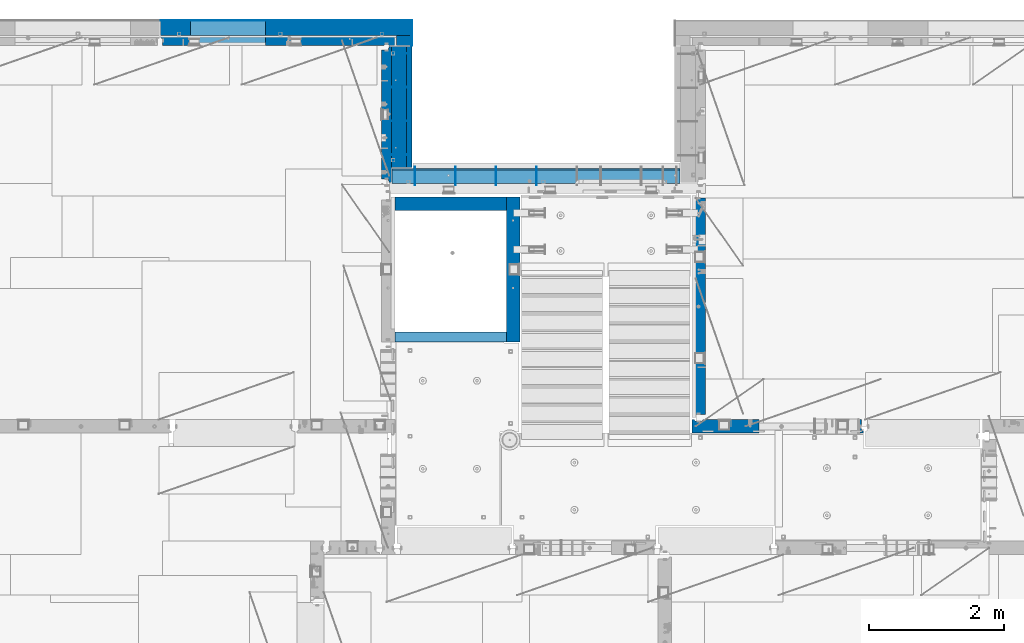
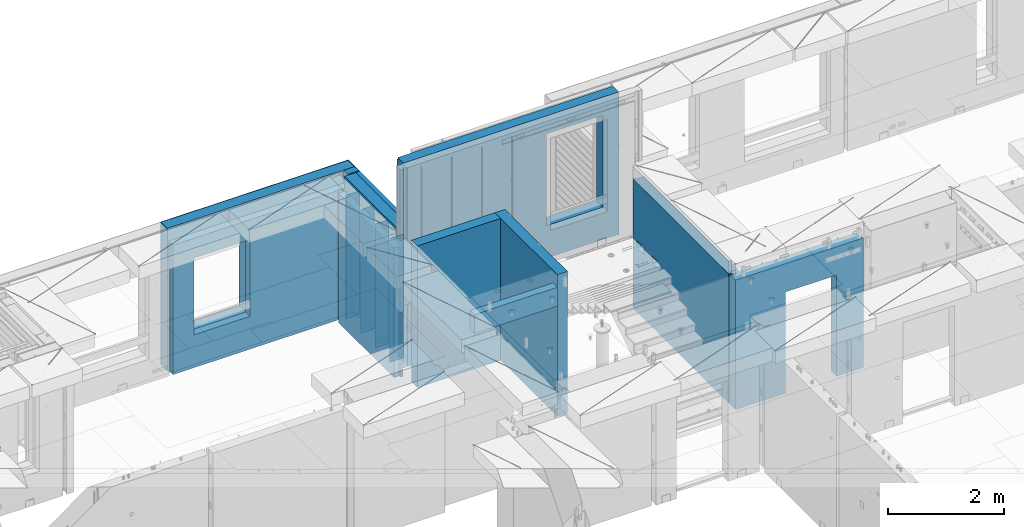
# One storey, part 237 of 349: 22 walls, 7 elements without a shape of their own.
"""IFC2X3 building model written with IfcOpenShell, lengths in millimetres."""

import ifcopenshell
import ifcopenshell.guid

model = None  # the IFC model being written
_history = None  # IfcOwnerHistory: only IFC2X3 demands one
_inside = {}  # id of a spatial element -> (the spatial element, [elements in it])
_under = {}  # id of a project, library or spatial element -> (it, [spatial elements below it])
_declared = {}  # id of a project -> (the project, [libraries it declares])
_typed = {}  # id of a type object -> (the type object, [elements of that type])
_made_of = {}  # id of a material, layer set ... -> (it, [elements and type objects made of it])


def new_model(schema):
    """Start an empty IFC model of exactly this schema.

    Asked for "IFC4X3", IfcOpenShell would pick the latest addendum, in which some entities
    have other attributes; the version numbers below select the first issue.
    IFC2X3 requires an IfcOwnerHistory on every rooted entity: one is made here for all.
    """
    global model, _history
    if schema == "IFC4X3":
        model = ifcopenshell.file(schema_version=(4, 3, 0, 0))
    else:
        model = ifcopenshell.file(schema=schema)
    _inside.clear()
    _under.clear()
    _declared.clear()
    _typed.clear()
    _made_of.clear()
    _history = None
    if model.schema == "IFC2X3":
        org = make("IfcOrganization", Name="unknown")
        user = make(
            "IfcPersonAndOrganization",
            ThePerson=make("IfcPerson", FamilyName="unknown"),
            TheOrganization=org,
        )
        app = make(
            "IfcApplication",
            ApplicationDeveloper=org,
            Version="unknown",
            ApplicationFullName="unknown",
            ApplicationIdentifier="unknown",
        )
        _history = make(
            "IfcOwnerHistory",
            OwningUser=user,
            OwningApplication=app,
            ChangeAction="ADDED",
            CreationDate=0,
        )
    return model


def make(cls, **values):
    """One entity of the class cls with the attributes given. An attribute that is None is left unset."""
    return model.create_entity(
        cls, **{name: value for name, value in values.items() if value is not None}
    )


def rooted(cls, **values):
    """An entity with a GlobalId (a new one), such as an element, a storey or a relation."""
    return make(cls, GlobalId=ifcopenshell.guid.new(), OwnerHistory=_history, **values)


def si_unit(unit_type, name, prefix=None):
    """IfcSIUnit, for example si_unit("LENGTHUNIT", "METRE", prefix="MILLI")."""
    return make("IfcSIUnit", UnitType=unit_type, Prefix=prefix, Name=name)


def assignment(units):
    """IfcUnitAssignment: the units of a project."""
    return None if units is None else make("IfcUnitAssignment", Units=units)


def point(xyz):
    """IfcCartesianPoint."""
    return None if xyz is None else make("IfcCartesianPoint", Coordinates=xyz)


def direction(xyz):
    """IfcDirection."""
    return None if xyz is None else make("IfcDirection", DirectionRatios=xyz)


def frame(location, z_axis=None, x_axis=None):
    """IfcAxis2Placement3D, a coordinate frame: its origin and axes. An axis left out is left unset."""
    return make(
        "IfcAxis2Placement3D",
        Location=point(location),
        Axis=direction(z_axis),
        RefDirection=direction(x_axis),
    )


def origin_with_axes():
    """The frame at (0, 0, 0) with the z axis (0, 0, 1) and the x axis (1, 0, 0) written out."""
    return frame((0.0, 0.0, 0.0), z_axis=(0.0, 0.0, 1.0), x_axis=(1.0, 0.0, 0.0))


def place(relative_to, where):
    """IfcLocalPlacement: puts the frame where relative to a parent placement (None: the world)."""
    return make(
        "IfcLocalPlacement", PlacementRelTo=relative_to, RelativePlacement=where
    )


def context(
    kind, dimensions, precision=None, world=None, true_north=None, identifier=None
):
    """IfcGeometricRepresentationContext, for example the 3D "Model" context."""
    return make(
        "IfcGeometricRepresentationContext",
        ContextIdentifier=identifier,
        ContextType=kind,
        CoordinateSpaceDimension=dimensions,
        Precision=precision,
        WorldCoordinateSystem=world,
        TrueNorth=true_north,
    )


def subcontext(parent, identifier, kind, view, scale=None):
    """IfcGeometricRepresentationSubContext, for example "Body" below "Model"."""
    return make(
        "IfcGeometricRepresentationSubContext",
        ContextIdentifier=identifier,
        ContextType=kind,
        ParentContext=parent,
        TargetScale=scale,
        TargetView=view,
    )


def project(units=None, contexts=None):
    """IfcProject with its units and contexts."""
    return rooted(
        "IfcProject",
        Name="project",
        RepresentationContexts=contexts,
        UnitsInContext=assignment(units),
    )


def spatial(cls, under=None, at=None, **own):
    """A site, building, storey or space (cls), placed at a placement, below another one or the project."""
    s = rooted(cls, ObjectPlacement=at, **own)
    if under is not None:
        _under.setdefault(under.id(), (under, []))[1].append(s)
    return s


def faces_of(points, faces, orient=None, outer=None):
    """IfcFace entities. A face is a list of loops; a loop is a list of indices into points, from 0.

    orient and outer hold one flag for each loop. By default every Orientation is true, the
    first loop of a face is its IfcFaceOuterBound and the others are IfcFaceBound.
    """
    made = []
    for i, loops in enumerate(faces):
        bounds = []
        for j, loop in enumerate(loops):
            is_outer = j == 0 if outer is None else outer[i][j]
            bounds.append(
                make(
                    "IfcFaceOuterBound" if is_outer else "IfcFaceBound",
                    Bound=make("IfcPolyLoop", Polygon=[points[k] for k in loop]),
                    Orientation=True if orient is None else orient[i][j],
                )
            )
        made.append(make("IfcFace", Bounds=bounds))
    return made


def faceted_brep(points, faces, orient=None, outer=None, voids=None):
    """IfcFacetedBrep: a solid bounded by flat faces; with voids (closed shells), ...WithVoids."""
    shared = [point(p) for p in points]
    hull = make("IfcClosedShell", CfsFaces=faces_of(shared, faces, orient, outer))
    if voids is None:
        return make("IfcFacetedBrep", Outer=hull)
    return make(
        "IfcFacetedBrepWithVoids",
        Outer=hull,
        Voids=[
            make(cls, CfsFaces=faces_of(shared, fs, o, b)) for cls, fs, o, b in voids
        ],
    )


def shape(context_of_items, identifier, shape_type, items):
    """IfcShapeRepresentation: the items that make up one representation, for example the "Body"."""
    return make(
        "IfcShapeRepresentation",
        ContextOfItems=context_of_items,
        RepresentationIdentifier=identifier,
        RepresentationType=shape_type,
        Items=items,
    )


def material(Name=None, Category=None):
    """IfcMaterial."""
    return make("IfcMaterial", Name=Name, Category=Category)


def made_of(thing, what):
    """Note that an element or type object is made of a material, layer set ...; save() writes the relation."""
    if what is not None:
        _made_of.setdefault(what.id(), (what, []))[1].append(thing)
    return thing


def type_object(cls, material=None, **own):
    """A type object (cls), such as IfcWallType, which elements share."""
    return made_of(rooted(cls, **own), material)


def element(
    cls,
    number,
    at=None,
    inside=None,
    cuts=None,
    type_object=None,
    material=None,
    context=None,
    identifier="Body",
    shape_type=None,
    held_by="IfcProductDefinitionShape",
    body=None,
    shapes=None,
    **own,
):
    """One element of the class cls, such as IfcWall. Its Tag is "e" and its number.

    at: its placement. inside: the storey or other place that contains it. cuts: it is an
    opening in that element (IfcRelVoidsElement). A single representation is given by context,
    identifier, shape_type and body (its items); several are given by shapes. held_by: the class
    of the entity that holds the representations. save() writes the other relations.
    """
    e = rooted(cls, Tag="e%d" % number, ObjectPlacement=at, **own)
    if body is not None:
        shapes = [shape(context, identifier, shape_type, body)]
    if shapes is not None:
        e.Representation = make(held_by, Representations=shapes)
    if inside is not None:
        _inside.setdefault(inside.id(), (inside, []))[1].append(e)
    if cuts is not None:
        rooted(
            "IfcRelVoidsElement", RelatingBuildingElement=cuts, RelatedOpeningElement=e
        )
    if type_object is not None:
        _typed.setdefault(type_object.id(), (type_object, []))[1].append(e)
    return made_of(e, material)


def aggregate(whole, parts):
    """IfcRelAggregates: a whole, such as a stair, and the parts it consists of."""
    return rooted("IfcRelAggregates", RelatingObject=whole, RelatedObjects=parts)


def save(model, path):
    """Write the relations noted so far, then the file.

    IfcRelAggregates (storeys below a building ...), IfcRelContainedInSpatialStructure (elements
    in a storey), IfcRelDefinesByType, IfcRelAssociatesMaterial and IfcRelDeclares: one each for
    every whole, place, type object, material and project.
    """
    for whole, parts in _under.values():
        aggregate(whole, parts)
    for where, things in _inside.values():
        rooted(
            "IfcRelContainedInSpatialStructure",
            RelatedElements=things,
            RelatingStructure=where,
        )
    for kind, things in _typed.values():
        rooted("IfcRelDefinesByType", RelatedObjects=things, RelatingType=kind)
    for what, things in _made_of.values():
        rooted("IfcRelAssociatesMaterial", RelatedObjects=things, RelatingMaterial=what)
    for by, libraries in _declared.values():
        rooted("IfcRelDeclares", RelatingContext=by, RelatedDefinitions=libraries)
    model.write(path)


model = new_model("IFC2X3")

# Units and contexts
model_context = context("Model", 3, precision=1e-05, world=origin_with_axes())
body_context = subcontext(model_context, "Body", "Model", "MODEL_VIEW")
ifc_project = project(units=[si_unit("LENGTHUNIT", "METRE", prefix="MILLI"), si_unit("AREAUNIT", "SQUARE_METRE"), si_unit("VOLUMEUNIT", "CUBIC_METRE"), si_unit("MASSUNIT", "GRAM", prefix="KILO"), si_unit("TIMEUNIT", "SECOND"), si_unit("PLANEANGLEUNIT", "RADIAN"), si_unit("SOLIDANGLEUNIT", "STERADIAN"), si_unit("THERMODYNAMICTEMPERATUREUNIT", "DEGREE_CELSIUS"), si_unit("LUMINOUSINTENSITYUNIT", "LUMEN")], contexts=[model_context])

# Site, building, storey
site_placement = place(None, origin_with_axes())
site = spatial("IfcSite", under=ifc_project, at=site_placement, CompositionType="ELEMENT")
building_placement = place(site_placement, origin_with_axes())
building = spatial("IfcBuilding", under=site, at=building_placement, CompositionType="ELEMENT")
storey_placement = place(building_placement, origin_with_axes())
storey = spatial("IfcBuildingStorey", under=building, at=storey_placement, Name="4", CompositionType="ELEMENT", Elevation=0.0)

# Assembly, walls
assembly_1_placement = place(storey_placement, origin_with_axes())
assembly_1 = element("IfcElementAssembly", 1, at=assembly_1_placement, inside=storey, AssemblyPlace="NOTDEFINED", PredefinedType="REINFORCEMENT_UNIT")
ifc_material_1 = material(Name="Undefined")
wall_type_1 = type_object("IfcWallType", PredefinedType="NOTDEFINED")
wall_1_placement = place(assembly_1_placement, frame((17730.0, 21005.0, 92115.0), z_axis=(0.0, 0.0, 1.0), x_axis=(1.0, 0.0, 0.0)))
wall_1 = element("IfcWall", 2, at=wall_1_placement, type_object=wall_type_1, material=ifc_material_1, Name="(PD)", context=body_context, shape_type="Brep", body=[
    faceted_brep([(0.0, 5.0, -1300.0), (0.0, 5.0, 1300.0), (280.0, 5.0, 1300.0), (280.0, 5.0, -1300.0), (0.0, -5.0, 1300.0), (280.0, -5.0, 1300.0), (0.0, -5.0, -1300.0), (280.0, -5.0, -1300.0)], [[[0, 1, 2, 3]], [[1, 4, 5, 2]], [[4, 6, 7, 5]], [[6, 0, 3, 7]], [[5, 7, 3, 2]], [[6, 4, 1, 0]]]),
])
wall_2_placement = place(assembly_1_placement, frame((17730.0, 21505.0, 92115.0), z_axis=(0.0, 0.0, 1.0), x_axis=(1.0, 0.0, 0.0)))
wall_2 = element("IfcWall", 3, at=wall_2_placement, type_object=wall_type_1, material=ifc_material_1, Name="(PD)", context=body_context, shape_type="Brep", body=[
    faceted_brep([(0.0, 5.0, -1300.0), (0.0, 5.0, 1300.0), (280.0, 5.0, 1300.0), (280.0, 5.0, -1300.0), (0.0, -5.0, 1300.0), (280.0, -5.0, 1300.0), (0.0, -5.0, -1300.0), (280.0, -5.0, -1300.0)], [[[0, 1, 2, 3]], [[1, 4, 5, 2]], [[4, 6, 7, 5]], [[6, 0, 3, 7]], [[5, 7, 3, 2]], [[6, 4, 1, 0]]]),
])
wall_3_placement = place(assembly_1_placement, frame((17730.0, 22005.0, 92115.0), z_axis=(0.0, 0.0, 1.0), x_axis=(1.0, 0.0, 0.0)))
wall_3 = element("IfcWall", 4, at=wall_3_placement, type_object=wall_type_1, material=ifc_material_1, Name="(PD)", context=body_context, shape_type="Brep", body=[
    faceted_brep([(0.0, 5.0, -1300.0), (0.0, 5.0, 1300.0), (280.0, 5.0, 1300.0), (280.0, 5.0, -1300.0), (0.0, -5.0, 1300.0), (280.0, -5.0, 1300.0), (0.0, -5.0, -1300.0), (280.0, -5.0, -1300.0)], [[[0, 1, 2, 3]], [[1, 4, 5, 2]], [[4, 6, 7, 5]], [[6, 0, 3, 7]], [[5, 7, 3, 2]], [[6, 4, 1, 0]]]),
])

assembly_2_placement = place(storey_placement, origin_with_axes())
assembly_2 = element("IfcElementAssembly", 5, at=assembly_2_placement, inside=storey, AssemblyPlace="NOTDEFINED", PredefinedType="REINFORCEMENT_UNIT")
wall_4_placement = place(assembly_2_placement, frame((18110.0002441406, 20550.0, 93745.0), z_axis=(0.0, 0.0, 1.0), x_axis=(0.0, 1.0, 0.0)))
wall_4 = element("IfcWall", 6, at=wall_4_placement, type_object=wall_type_1, material=ifc_material_1, Name="(PD)", context=body_context, shape_type="Brep", body=[
    faceted_brep([(0.0, 5.0, -1300.0), (0.0, 5.0, 1300.0), (280.0, 5.0, 1300.0), (280.0, 5.0, -1300.0), (0.0, -5.0, 1300.0), (280.0, -5.0, 1300.0), (0.0, -5.0, -1300.0), (280.0, -5.0, -1300.0)], [[[0, 1, 2, 3]], [[1, 4, 5, 2]], [[4, 6, 7, 5]], [[6, 0, 3, 7]], [[5, 7, 3, 2]], [[6, 4, 1, 0]]]),
])
wall_5_placement = place(assembly_2_placement, frame((18710.0002441406, 20550.0, 93745.0), z_axis=(0.0, 0.0, 1.0), x_axis=(0.0, 1.0, 0.0)))
wall_5 = element("IfcWall", 7, at=wall_5_placement, type_object=wall_type_1, material=ifc_material_1, Name="(PD)", context=body_context, shape_type="Brep", body=[
    faceted_brep([(0.0, 5.0, -1300.0), (0.0, 5.0, 1300.0), (280.0, 5.0, 1300.0), (280.0, 5.0, -1300.0), (0.0, -5.0, 1300.0), (280.0, -5.0, 1300.0), (0.0, -5.0, -1300.0), (280.0, -5.0, -1300.0)], [[[0, 1, 2, 3]], [[1, 4, 5, 2]], [[4, 6, 7, 5]], [[6, 0, 3, 7]], [[5, 7, 3, 2]], [[6, 4, 1, 0]]]),
])
wall_6_placement = place(assembly_2_placement, frame((19310.0002441406, 20550.0, 93745.0), z_axis=(0.0, 0.0, 1.0), x_axis=(0.0, 1.0, 0.0)))
wall_6 = element("IfcWall", 8, at=wall_6_placement, type_object=wall_type_1, material=ifc_material_1, Name="(PD)", context=body_context, shape_type="Brep", body=[
    faceted_brep([(0.0, 5.0, -1300.0), (0.0, 5.0, 1300.0), (280.0, 5.0, 1300.0), (280.0, 5.0, -1300.0), (0.0, -5.0, 1300.0), (280.0, -5.0, 1300.0), (0.0, -5.0, -1300.0), (280.0, -5.0, -1300.0)], [[[0, 1, 2, 3]], [[1, 4, 5, 2]], [[4, 6, 7, 5]], [[6, 0, 3, 7]], [[5, 7, 3, 2]], [[6, 4, 1, 0]]]),
])
wall_7_placement = place(assembly_2_placement, frame((19910.0002441406, 20550.0, 93745.0), z_axis=(0.0, 0.0, 1.0), x_axis=(0.0, 1.0, 0.0)))
wall_7 = element("IfcWall", 9, at=wall_7_placement, type_object=wall_type_1, material=ifc_material_1, Name="(PD)", context=body_context, shape_type="Brep", body=[
    faceted_brep([(0.0, 5.0, -1300.0), (0.0, 5.0, 1300.0), (280.0, 5.0, 1300.0), (280.0, 5.0, -1300.0), (0.0, -5.0, 1300.0), (280.0, -5.0, 1300.0), (0.0, -5.0, -1300.0), (280.0, -5.0, -1300.0)], [[[0, 1, 2, 3]], [[1, 4, 5, 2]], [[4, 6, 7, 5]], [[6, 0, 3, 7]], [[5, 7, 3, 2]], [[6, 4, 1, 0]]]),
])

# Wall
wall_8_placement = place(assembly_1_placement, frame((17730.0, 22505.0, 92115.0), z_axis=(0.0, 0.0, 1.0), x_axis=(1.0, 0.0, 0.0)))
wall_8 = element("IfcWall", 10, at=wall_8_placement, type_object=wall_type_1, material=ifc_material_1, Name="(PD)", context=body_context, shape_type="Brep", body=[
    faceted_brep([(0.0, 5.0, -1300.0), (0.0, 5.0, 1300.0), (280.0, 5.0, 1300.0), (280.0, 5.0, -1300.0), (0.0, -5.0, 1300.0), (280.0, -5.0, 1300.0), (0.0, -5.0, -1300.0), (280.0, -5.0, -1300.0)], [[[0, 1, 2, 3]], [[1, 4, 5, 2]], [[4, 6, 7, 5]], [[6, 0, 3, 7]], [[5, 7, 3, 2]], [[6, 4, 1, 0]]]),
])

# Assembly, wall
assembly_3_placement = place(storey_placement, origin_with_axes())
assembly_3 = element("IfcElementAssembly", 11, at=assembly_3_placement, inside=storey, AssemblyPlace="NOTDEFINED", PredefinedType="REINFORCEMENT_UNIT")
ifc_material_2 = material(Name="CONCRETE/C25/30")
wall_type_2 = type_object("IfcWallType", PredefinedType="NOTDEFINED")
wall_9_placement = place(assembly_3_placement, frame((22310.0, 16980.0, 92112.5), z_axis=(0.0, 0.0, 1.0), x_axis=(1.0, 0.0, 0.0)))
wall_9 = element("IfcWall", 12, at=wall_9_placement, type_object=wall_type_2, material=ifc_material_2, context=body_context, shape_type="Brep", body=[
    faceted_brep([(890.000686645508, 100.0, 762.5), (890.000686645508, -100.0, 762.5), (890.000686645508, -100.0, -1357.5), (890.000686645508, 100.0, -1357.5), (1910.00068664551, 100.0, 762.5), (1910.00068664551, -100.0, 762.5), (1910.00068664551, 100.0, -1357.5), (1910.00068664551, -100.0, -1357.5), (-100.0, -100.0, -1357.5), (-100.0, -100.0, 1357.5), (-100.0, 100.0, 1357.5), (-100.0, 100.0, -1357.5), (2440.0, -100.0, 1357.5), (2440.0, -100.0, -1357.5), (2440.0, -70.0000000000036, -1357.5), (2440.0, -70.0000000000036, 1357.5), (2410.0, 100.0, 1357.5), (2410.0, -57.0, 1357.5), (2410.0, -57.0, -1357.5), (2410.0, 100.0, -1357.5), (65.0000000000036, 100.0, 1357.5), (52.0, 80.0, 1357.5), (-52.0, 80.0, 1357.5), (-65.0, 100.0, 1357.5), (-65.0, 100.0, -1357.5), (-52.0, 80.0, -1357.5), (52.0, 80.0, -1357.5), (65.0000000000036, 100.0, -1357.5)], [[[0, 1, 2, 3]], [[4, 5, 1, 0]], [[6, 7, 5, 4]], [[8, 9, 10, 11]], [[12, 13, 14, 15]], [[16, 17, 18, 19]], [[15, 14, 18, 17]], [[16, 20, 21, 22, 23, 10, 9, 12, 15, 17]], [[11, 10, 23, 24]], [[22, 25, 24, 23]], [[21, 26, 25, 22]], [[20, 27, 26, 21]], [[8, 11, 24, 25, 26, 27, 3, 2]], [[13, 12, 9, 8, 2, 1, 5, 7]], [[19, 18, 14, 13, 7, 6]], [[3, 27, 20, 16, 19, 6, 4, 0]]]),
])
aggregate(assembly_3, [wall_9])

assembly_4_placement = place(storey_placement, origin_with_axes())
assembly_4 = element("IfcElementAssembly", 13, at=assembly_4_placement, inside=storey, AssemblyPlace="NOTDEFINED", PredefinedType="REINFORCEMENT_UNIT")
wall_10_placement = place(assembly_4_placement, frame((22310.0, 16980.0, 92112.5), z_axis=(0.0, 0.0, 1.0), x_axis=(0.0, 1.0, 0.0)))
wall_10 = element("IfcWall", 14, at=wall_10_placement, type_object=wall_type_2, material=ifc_material_2, context=body_context, shape_type="Brep", body=[
    faceted_brep([(3059.9952678883, 0.0998642726626713, 102.5), (3259.9952678883, 0.0998642726626713, 102.5), (3259.9952678883, 0.0998642726626713, -7.5), (3059.9952678883, 0.0998642726626713, -7.5), (3034.9952678883, 100.099864272663, -7.5), (3284.9952678883, 100.099864272663, -7.5), (3034.9952678883, 100.099864272663, 137.5), (3284.9952678883, 100.099864272663, 137.5), (3420.0, 70.0, 1357.5), (3420.0, 100.0, 1357.5), (130.0, 100.0, 1357.5), (130.0, 70.0, 1357.5), (180.0, 57.0, 1357.5), (180.0, -100.0, 1357.5), (3384.99999178648, -100.000000948603, 1357.5), (3385.00000172571, 57.0000007519884, 1357.5), (130.0, 100.0, -1357.5), (130.0, 70.0, -1357.5), (180.0, 57.0, -1357.5), (180.0, -100.0, -1357.5), (3384.99999178648, -100.0, -1357.5), (3385.00000172571, 57.0000007519884, -1357.5), (3420.0, 100.0, -1357.5), (3420.0, 70.0, -1357.5), (2519.9952678883, 0.0998642726626713, 102.5), (2719.9952678883, 0.0998642726626713, 102.5), (2719.9952678883, 0.0998642726626713, -7.5), (2519.9952678883, 0.0998642726626713, -7.5), (2744.9952678883, 100.099864272663, -7.5), (2744.9952678883, 100.099864272663, 137.5), (2494.9952678883, 100.099864272663, -7.5), (2494.9952678883, 100.099864272663, 137.5)], [[[0, 1, 2, 3]], [[4, 3, 2, 5]], [[6, 0, 3, 4]], [[7, 1, 0, 6]], [[5, 2, 1, 7]], [[8, 9, 10, 11, 12, 13, 14, 15]], [[10, 16, 17, 11]], [[11, 17, 18, 12]], [[13, 12, 18, 19]], [[13, 19, 20, 14]], [[14, 20, 21, 15]], [[19, 18, 17, 16, 22, 23, 21, 20]], [[15, 21, 23, 8]], [[22, 9, 8, 23]], [[24, 25, 26, 27]], [[28, 26, 25, 29]], [[30, 27, 26, 28]], [[31, 24, 27, 30]], [[29, 25, 24, 31]], [[16, 10, 9, 22], [4, 5, 7, 6], [30, 28, 29, 31]]]),
])
aggregate(assembly_4, [wall_10])

# Assembly
assembly_5_placement = place(assembly_2_placement, origin_with_axes())
assembly_5 = element("IfcElementAssembly", 15, at=assembly_5_placement, Name="Steel Assembly", AssemblyPlace="NOTDEFINED", PredefinedType="NOTDEFINED")

aggregate(assembly_2, [assembly_5, wall_4, wall_5, wall_6, wall_7])

# Wall
ifc_material_3 = material(Name="COS5gt")
wall_type_3 = type_object("IfcWallType", PredefinedType="NOTDEFINED")
wall_11_placement = place(assembly_5_placement, frame((17765.0, 20690.0, 93747.5), z_axis=(0.0, 0.0, 1.0), x_axis=(1.0, 0.0, 0.0)))
wall_11 = element("IfcWall", 16, at=wall_11_placement, type_object=wall_type_3, material=ifc_material_3, context=body_context, shape_type="Brep", body=[
    faceted_brep([(0.0, -110.0, 1492.5), (4270.0, -110.0, 1492.5), (4270.0, 90.0, 1492.5), (0.0, 90.0, 1492.5), (4270.0, 110.0, 1442.5), (4270.0, 90.0, 1442.5), (4270.0, -110.0, -1492.5), (4270.0, 90.0, -1492.5), (4270.0, 90.0, -1442.5), (4270.0, 110.0, -1442.5), (0.0, 110.0, 1442.5), (0.0, 110.0, -1442.5), (2839.99840497971, 109.999997720995, -802.5), (2839.99840497971, 109.999997720995, -807.5), (2869.99840497971, 109.999997720995, -807.5), (3919.99840497971, 109.999997720995, -807.5), (3949.99840497971, 109.999997720995, -807.5), (3949.99840497971, 109.999997720995, -802.5), (3949.99840497971, 109.999997720995, 1107.5), (2839.99840497971, 109.999997720995, 1107.5), (2834.05245909535, -110.0, 1113.44594588435), (3955.94435086406, -110.0, 1113.44594588435), (2834.05245909535, -110.0, -813.445945884348), (3955.94435086406, -110.0, -813.445945884348), (0.0, -110.0, -1492.5), (0.0, 90.0, -1492.5), (0.0, 90.0, -1442.5), (0.0, 90.0, 1442.5)], [[[0, 1, 2, 3]], [[4, 5, 2, 1, 6, 7, 8, 9]], [[10, 4, 9, 11], [12, 13, 14, 15, 16, 17, 18, 19]], [[20, 19, 18, 21]], [[12, 19, 20, 22, 13]], [[23, 16, 15, 14, 13, 22]], [[21, 18, 17, 16, 23]], [[0, 24, 6, 1], [22, 20, 21, 23]], [[6, 24, 25, 7]], [[7, 25, 26, 8]], [[9, 8, 26, 11]], [[25, 24, 0, 3, 27, 10, 11, 26]], [[2, 5, 27, 3]], [[4, 10, 27, 5]]]),
])

aggregate(assembly_5, [wall_11])

wall_12_placement = place(assembly_1_placement, frame((17870.0, 22605.0, 92247.5), z_axis=(0.0, 0.0, 1.0), x_axis=(0.0, -1.0, 0.0)))
wall_12 = element("IfcWall", 17, at=wall_12_placement, type_object=wall_type_3, material=ifc_material_3, context=body_context, shape_type="Brep", body=[
    faceted_brep([(0.0, 110.0, -1492.5), (0.0, 110.0, 1492.5), (1790.0, 110.0, 1492.5), (1790.0, 110.0, -1492.5), (0.0, -110.0, 1492.5), (1790.0, -110.0, 1492.5), (0.0, -110.0, -1492.5), (1790.0, -110.0, -1492.5)], [[[0, 1, 2, 3]], [[1, 4, 5, 2]], [[4, 6, 7, 5]], [[6, 0, 3, 7]], [[5, 7, 3, 2]], [[6, 4, 1, 0]]]),
])

# Assembly, walls
assembly_6_placement = place(storey_placement, origin_with_axes())
assembly_6 = element("IfcElementAssembly", 18, at=assembly_6_placement, inside=storey, AssemblyPlace="NOTDEFINED", PredefinedType="REINFORCEMENT_UNIT")
ifc_material_4 = material()
wall_13_placement = place(assembly_6_placement, frame((17945.0, 22770.0, 92247.5), z_axis=(0.0, 0.0, 1.0), x_axis=(0.0, -1.0, 0.0)))
wall_13 = element("IfcWall", 19, at=wall_13_placement, type_object=wall_type_3, material=ifc_material_4, context=body_context, shape_type="Brep", body=[
    faceted_brep([(0.0, 110.0, -1492.5), (0.0, 110.0, 1492.5), (150.0, 110.0, 1492.5), (150.0, 110.0, -1492.5), (0.0, -110.0, 1492.5), (150.0, -110.0, 1492.5), (0.0, -110.0, -1492.5), (150.0, -110.0, -1492.5)], [[[0, 1, 2, 3]], [[1, 4, 5, 2]], [[4, 6, 7, 5]], [[6, 0, 3, 7]], [[5, 7, 3, 2]], [[6, 4, 1, 0]]]),
])
wall_14_placement = place(assembly_6_placement, frame((14340.0, 22880.0, 92247.5), z_axis=(0.0, 0.0, 1.0), x_axis=(1.0, 0.0, 0.0)))
wall_14 = element("IfcWall", 20, at=wall_14_placement, type_object=wall_type_3, material=ifc_material_4, context=body_context, shape_type="Brep", body=[
    faceted_brep([(0.0, -110.0, -1492.5), (0.0, 110.0, -1492.5), (3715.0, 110.0, -1492.5), (3715.0, -110.0, -1492.5), (0.0, -110.0, 1492.5), (0.0, 110.0, 1492.5), (3715.0, -110.0, 1492.5), (3715.0, 110.0, 1492.5), (444.999978713578, 110.0, -802.5), (1554.99997871358, 110.0, -802.5), (1554.99997871358, 110.0, 807.5), (444.999978713578, 110.0, 807.5), (444.999978713578, -110.0, -802.5), (444.999978713578, -110.0, 807.5), (1554.99997871358, -110.0, 807.5), (1554.99997871358, -110.0, -802.5)], [[[0, 1, 2, 3]], [[0, 4, 5, 1]], [[5, 4, 6, 7]], [[1, 5, 7, 2], [8, 9, 10, 11]], [[6, 3, 2, 7]], [[4, 0, 3, 6], [12, 13, 14, 15]], [[10, 14, 13, 11]], [[9, 15, 14, 10]], [[8, 12, 15, 9]], [[11, 13, 12, 8]]]),
])

# Wall
ifc_material_5 = material(Name="CONCRETE/C30/37")
wall_type_4 = type_object("IfcWallType", PredefinedType="NOTDEFINED")
wall_15_placement = place(assembly_1_placement, frame((18022.5, 22620.0, 92247.5), z_axis=(0.0, 0.0, 1.0), x_axis=(0.0, -1.0, 0.0)))
wall_15 = element("IfcWall", 21, at=wall_15_placement, type_object=wall_type_4, material=ifc_material_5, context=body_context, shape_type="Brep", body=[
    faceted_brep([(15.0, 42.5, 1342.99999994476), (15.0, 32.4999992506928, 1344.9999999992), (1805.0, 32.5, 1345.0), (1805.0, 42.5, 1343.0), (15.0, 32.4999991126933, 1355.00000040043), (1805.0, 32.5, 1355.0), (15.0, 42.5, 1356.99999988925), (1805.0, 42.5, 1357.0), (15.0, 42.5, 1206.99999988925), (1805.0, 42.5, 1207.0), (1805.0, 32.5, 1205.0), (15.0000000000009, 32.4999991126933, 1205.00000040043), (1805.0, 32.5, 1195.0), (15.0000000000009, 32.4999992506928, 1194.9999999992), (15.0, 42.5, 1192.99999994476), (1805.0, 42.5, 1193.0), (1805.0, 42.5, 1057.0), (15.0, 42.5, 1056.99999988925), (1805.0, 32.5, 1055.0), (15.0, 32.4999991126933, 1055.00000040043), (1805.0, 32.5, 1045.0), (15.0, 32.4999992506928, 1044.9999999992), (15.0, 42.5, 1042.99999994476), (1805.0, 42.5, 1043.0), (1805.0, 42.5, 907.0), (15.0, 42.5, 906.999999889245), (1805.0, 32.5, 905.0), (15.0, 32.4999991126933, 905.000000400425), (1805.0, 32.5, 895.0), (15.0, 32.4999992506928, 894.9999999992), (15.0, 42.5, 892.999999944761), (1805.0, 42.5, 893.0), (1805.0, 42.5, 757.0), (15.0, 42.5, 756.999999889245), (1805.0, 32.5, 755.0), (15.0, 32.4999991126933, 755.000000400425), (1805.0, 32.5, 745.0), (15.0, 32.4999992506928, 744.9999999992), (15.0, 42.5, 742.999999944761), (1805.0, 42.5, 743.0), (1805.0, 42.5, 607.0), (15.0, 42.5, 606.999999889245), (1805.0, 32.5, 605.0), (15.0, 32.4999991126933, 605.000000400425), (1805.0, 32.5, 595.0), (15.0, 32.4999992506928, 594.9999999992), (15.0, 42.5, 592.999999944761), (1805.0, 42.5, 593.0), (1805.0, 42.5, 457.0), (15.0, 42.5, 456.999999889245), (1805.0, 32.5, 455.0), (15.0, 32.4999991126933, 455.000000400425), (1805.0, 32.5, 445.0), (15.0, 32.4999992506928, 444.9999999992), (15.0, 42.5, 442.999999944761), (1805.0, 42.5, 443.0), (1805.0, 42.5, 307.0), (15.0, 42.5, 306.999999889245), (1805.0, 32.5, 305.0), (15.0, 32.4999991126933, 305.000000400425), (1805.0, 32.5, 295.0), (15.0, 32.4999992506928, 294.9999999992), (15.0, 42.5, 292.999999944761), (1805.0, 42.5, 293.0), (1805.0, 42.5, 157.0), (15.0, 42.5, 156.999999889245), (1805.0, 32.5, 155.0), (15.0000000000009, 32.4999991126933, 155.000000400425), (1805.0, 32.5, 145.0), (15.0000000000009, 32.4999992506928, 144.9999999992), (15.0, 42.5, 142.999999944761), (1805.0, 42.5, 143.0), (1805.0, 42.5, 7.0), (15.0, 42.5, 6.99999988924537), (1805.0, 32.5, 5.0), (14.9999999999991, 32.4999991126933, 5.00000040042505), (1805.0, 32.5, -5.0), (14.9999999999991, 32.4999992506928, -5.00000000080036), (15.0, 42.5, -7.00000005523907), (1805.0, 42.5, -7.0), (1805.0, 42.5, -143.0), (15.0, 42.5, -143.000000110755), (1805.0, 32.5, -145.0), (15.0000000000009, 32.4999991126933, -144.999999599575), (1805.0, 32.5, -155.0), (15.0000000000009, 32.4999992506928, -155.0000000008), (15.0, 42.5, -157.000000055239), (1805.0, 42.5, -157.0), (1805.0, 42.5, -293.0), (15.0, 42.5, -293.000000110755), (1805.0, 32.5, -295.0), (15.0, 32.4999991126933, -294.999999599575), (1805.0, 32.5, -305.0), (15.0, 32.4999992506928, -305.0000000008), (15.0, 42.5, -307.000000055239), (1805.0, 42.5, -307.0), (1805.0, 42.5, -443.0), (15.0, 42.5, -443.000000110755), (1805.0, 32.5, -445.0), (15.0000000000009, 32.4999991126933, -444.999999599575), (1805.0, 32.5, -455.0), (15.0000000000009, 32.4999992506928, -455.0000000008), (15.0, 42.5, -457.000000055239), (1805.0, 42.5, -457.0), (1805.0, 42.5, -593.0), (15.0, 42.5, -593.000000110755), (1805.0, 32.5, -595.0), (15.0, 32.4999991126933, -594.999999599575), (1805.0, 32.5, -605.0), (15.0, 32.4999992506928, -605.0000000008), (15.0, 42.5, -607.000000055239), (1805.0, 42.5, -607.0), (1805.0, 42.5, -743.0), (15.0, 42.5, -743.000000110755), (1805.0, 32.5, -745.0), (15.0, 32.4999991126933, -744.999999599575), (1805.0, 32.5, -755.0), (15.0, 32.4999992506928, -755.0000000008), (15.0, 42.5, -757.000000055239), (1805.0, 42.5, -757.0), (1805.0, 42.5, -893.0), (15.0, 42.5, -893.000000110755), (1805.0, 32.5, -895.0), (15.0000000000009, 32.4999991126933, -894.999999599575), (1805.0, 32.5, -905.0), (15.0000000000009, 32.4999992506928, -905.0000000008), (15.0, 42.5, -907.000000055239), (1805.0, 42.5, -907.0), (1805.0, 42.5, -1043.0), (15.0, 42.5, -1043.00000011075), (1805.0, 32.5, -1045.0), (15.0, 32.4999991126933, -1044.99999959957), (1805.0, 32.5, -1055.0), (15.0, 32.4999992506928, -1055.0000000008), (15.0, 42.5, -1057.00000005524), (1805.0, 42.5, -1057.0), (1805.0, 42.5, -1193.0), (15.0, 42.5, -1193.00000011075), (1805.0, 32.5, -1195.0), (15.0, 32.4999991126933, -1194.99999959957), (1805.0, 32.5, -1205.0), (15.0, 32.4999992506928, -1205.0000000008), (15.0, 42.5, -1207.00000005524), (1805.0, 42.5, -1207.0), (1805.0, 42.5, -1343.0), (15.0, 42.5, -1343.00000011075), (1805.0, 32.5, -1345.0), (15.0, 32.4999991126933, -1344.99999959957), (1805.0, 32.5, -1355.0), (15.0, 32.4999992506928, -1355.0000000008), (15.0, 42.5, -1357.00000005524), (1805.0, 42.5, -1357.0), (1805.0, 42.5, -1492.5), (15.0, 42.5, -1492.5), (15.0, -42.5, -1492.5), (1805.0, -42.5, -1492.5), (15.0, -42.5, 1492.5), (1805.0, -42.5, 1492.5), (15.0, 42.5, 1492.5), (1805.0, 42.5, 1492.5)], [[[0, 1, 2, 3]], [[4, 5, 2, 1]], [[6, 7, 5, 4]], [[8, 9, 10, 11]], [[11, 10, 12, 13]], [[14, 13, 12, 15]], [[16, 17, 14, 15]], [[17, 16, 18, 19]], [[19, 18, 20, 21]], [[22, 21, 20, 23]], [[24, 25, 22, 23]], [[25, 24, 26, 27]], [[27, 26, 28, 29]], [[30, 29, 28, 31]], [[32, 33, 30, 31]], [[33, 32, 34, 35]], [[35, 34, 36, 37]], [[38, 37, 36, 39]], [[40, 41, 38, 39]], [[41, 40, 42, 43]], [[43, 42, 44, 45]], [[46, 45, 44, 47]], [[48, 49, 46, 47]], [[49, 48, 50, 51]], [[51, 50, 52, 53]], [[54, 53, 52, 55]], [[56, 57, 54, 55]], [[57, 56, 58, 59]], [[59, 58, 60, 61]], [[62, 61, 60, 63]], [[64, 65, 62, 63]], [[65, 64, 66, 67]], [[67, 66, 68, 69]], [[70, 69, 68, 71]], [[72, 73, 70, 71]], [[73, 72, 74, 75]], [[75, 74, 76, 77]], [[78, 77, 76, 79]], [[80, 81, 78, 79]], [[81, 80, 82, 83]], [[83, 82, 84, 85]], [[86, 85, 84, 87]], [[88, 89, 86, 87]], [[89, 88, 90, 91]], [[91, 90, 92, 93]], [[94, 93, 92, 95]], [[96, 97, 94, 95]], [[97, 96, 98, 99]], [[99, 98, 100, 101]], [[102, 101, 100, 103]], [[104, 105, 102, 103]], [[105, 104, 106, 107]], [[107, 106, 108, 109]], [[110, 109, 108, 111]], [[112, 113, 110, 111]], [[113, 112, 114, 115]], [[115, 114, 116, 117]], [[118, 117, 116, 119]], [[120, 121, 118, 119]], [[121, 120, 122, 123]], [[123, 122, 124, 125]], [[126, 125, 124, 127]], [[128, 129, 126, 127]], [[129, 128, 130, 131]], [[131, 130, 132, 133]], [[134, 133, 132, 135]], [[136, 137, 134, 135]], [[137, 136, 138, 139]], [[139, 138, 140, 141]], [[142, 141, 140, 143]], [[144, 145, 142, 143]], [[145, 144, 146, 147]], [[147, 146, 148, 149]], [[150, 149, 148, 151]], [[152, 153, 150, 151]], [[154, 153, 152, 155]], [[156, 154, 155, 157]], [[158, 156, 157, 159]], [[1, 0, 8, 11, 13, 14, 17, 19, 21, 22, 25, 27, 29, 30, 33, 35, 37, 38, 41, 43, 45, 46, 49, 51, 53, 54, 57, 59, 61, 62, 65, 67, 69, 70, 73, 75, 77, 78, 81, 83, 85, 86, 89, 91, 93, 94, 97, 99, 101, 102, 105, 107, 109, 110, 113, 115, 117, 118, 121, 123, 125, 126, 129, 131, 133, 134, 137, 139, 141, 142, 145, 147, 149, 150, 153, 154, 156, 158, 6, 4]], [[9, 8, 0, 3]], [[159, 157, 155, 152, 151, 148, 146, 144, 143, 140, 138, 136, 135, 132, 130, 128, 127, 124, 122, 120, 119, 116, 114, 112, 111, 108, 106, 104, 103, 100, 98, 96, 95, 92, 90, 88, 87, 84, 82, 80, 79, 76, 74, 72, 71, 68, 66, 64, 63, 60, 58, 56, 55, 52, 50, 48, 47, 44, 42, 40, 39, 36, 34, 32, 31, 28, 26, 24, 23, 20, 18, 16, 15, 12, 10, 9, 3, 2, 5, 7]], [[158, 159, 7, 6]]]),
])

wall_type_5 = type_object("IfcWallType", PredefinedType="NOTDEFINED")
wall_16_placement = place(assembly_1_placement, frame((17685.0, 22605.0, 92112.5), z_axis=(0.0, 0.0, 1.0), x_axis=(0.0, -1.0, 0.0)))
wall_16 = element("IfcWall", 22, at=wall_16_placement, type_object=wall_type_5, material=ifc_material_2, context=body_context, shape_type="Brep", body=[
    faceted_brep([(1959.99999772087, -75.0, 1357.5), (1959.99999772087, -75.0, -1357.5), (1959.99999772087, 27.0, -1357.5), (1959.99999772087, 27.0, 1357.5), (2009.99999772087, 40.0, -1357.5), (2009.99999772087, 40.0, 1357.5), (50.0, -75.0, 1357.5), (50.0, 27.0, 1357.5), (50.0, 27.0, -1357.5), (50.0, -75.0, -1357.5), (0.0, 40.0, 1357.5), (0.0, 40.0, -1357.5), (0.0, 75.0, 1357.5), (0.0, 75.0, -1357.5), (2009.99999772087, 75.0, 1357.5), (2009.99999772087, 75.0, -1357.5)], [[[0, 1, 2, 3]], [[3, 2, 4, 5]], [[6, 7, 8, 9]], [[10, 11, 8, 7]], [[12, 13, 11, 10]], [[13, 12, 14, 15]], [[15, 14, 5, 4]], [[11, 13, 15, 4, 2, 1, 9, 8]], [[1, 0, 6, 9]], [[0, 3, 5, 14, 12, 10, 7, 6]]]),
])

aggregate(assembly_1, [wall_12, wall_1, wall_2, wall_3, wall_8, wall_15, wall_16])

wall_17_placement = place(assembly_6_placement, frame((14340.0, 22695.0, 92112.5), z_axis=(0.0, 0.0, 1.0), x_axis=(1.0, 0.0, 0.0)))
wall_17 = element("IfcWall", 23, at=wall_17_placement, type_object=wall_type_5, material=ifc_material_2, context=body_context, shape_type="Brep", body=[
    faceted_brep([(444.999978713578, 75.0, 942.5), (444.999978713578, -75.0, 942.5), (444.999978713578, -75.0, -667.5), (444.999978713578, 75.0, -667.5), (1554.99997871358, -75.0, -667.5), (1554.99997871358, 75.0, -667.5), (1554.99997871358, -75.0, 942.5), (1554.99997871358, 75.0, 942.5), (3305.0, -75.0, 1357.5), (3318.00000041054, -54.9999993903439, 1357.5), (3372.00000031511, -54.9999994175341, 1357.5), (3385.00000278453, -75.0000022791319, 1357.5), (3495.0, -75.0, 1357.5), (3495.0, 75.0, 1357.5), (0.0, 75.0, 1357.5), (0.0, 45.0, 1357.5), (30.0000010550393, 24.9999970131248, 1357.5), (30.0000016637459, -75.0, 1357.5), (3305.0, -75.0, -1357.5), (3318.00000041054, -54.9999993903439, -1357.5), (3372.00000031511, -54.9999994175341, -1357.5), (3385.00000278453, -75.0, -1357.5), (3495.0, -75.0, -1357.5), (3495.0, 75.0, -1357.5), (0.0, 75.0, -1357.5), (0.0, 45.0, -1357.5), (30.0000010550393, 24.9999970131248, -1357.49999999999), (30.0000016637459, -75.0, -1357.5)], [[[0, 1, 2, 3]], [[3, 2, 4, 5]], [[5, 4, 6, 7]], [[7, 6, 1, 0]], [[8, 9, 10, 11, 12, 13, 14, 15, 16, 17]], [[8, 18, 19, 9]], [[9, 19, 20, 10]], [[11, 10, 20, 21]], [[22, 12, 11, 21]], [[12, 22, 23, 13]], [[24, 14, 13, 23], [3, 5, 7, 0]], [[14, 24, 25, 15]], [[15, 25, 26, 16]], [[24, 23, 22, 21, 20, 19, 18, 27, 26, 25]], [[16, 26, 27, 17]], [[18, 8, 17, 27], [2, 1, 6, 4]]]),
])

# Assembly, walls
assembly_7_placement = place(storey_placement, origin_with_axes())
assembly_7 = element("IfcElementAssembly", 24, at=assembly_7_placement, inside=storey, AssemblyPlace="NOTDEFINED", PredefinedType="REINFORCEMENT_UNIT")
wall_type_6 = type_object("IfcWallType", PredefinedType="NOTDEFINED")
wall_18_placement = place(assembly_7_placement, frame((17809.9999105288, 20280.0000293051, 92242.5), z_axis=(0.0, 0.0, 1.0), x_axis=(1.0, 0.0, 0.0)))
wall_18 = element("IfcWall", 25, at=wall_18_placement, type_object=wall_type_6, material=ifc_material_2, context=body_context, shape_type="Brep", body=[
    faceted_brep([(0.0, 100.0, -1487.5), (0.0, 100.0, 1487.5), (1649.99977111816, 100.0, 1487.5), (1649.99977111816, 100.0, -1487.5), (0.0, -100.0, 1487.5), (1649.99977111816, -100.0, 1487.5), (0.0, -100.0, -1487.5), (1649.99977111816, -100.0, -1487.5)], [[[0, 1, 2, 3]], [[1, 4, 5, 2]], [[4, 6, 7, 5]], [[6, 0, 3, 7]], [[5, 7, 3, 2]], [[6, 4, 1, 0]]]),
])
wall_19_placement = place(assembly_7_placement, frame((19559.999681647, 18229.9992663657, 92242.5), z_axis=(0.0, 0.0, 1.0), x_axis=(0.0, 1.0, 0.0)))
wall_19 = element("IfcWall", 26, at=wall_19_placement, type_object=wall_type_6, material=ifc_material_2, context=body_context, shape_type="Brep", body=[
    faceted_brep([(1470.00546574604, -0.100182625668822, -27.5), (1270.00546574604, -0.100182625668822, -27.5), (1270.00546574604, -0.100182625668822, -137.5), (1470.00546574604, -0.100182625668822, -137.5), (1245.00546574604, -100.100182625669, -137.5), (1245.00546574604, -100.100182625669, 7.5), (1495.00546574604, -100.100182625669, -137.5), (1495.00546574604, -100.100182625669, 7.5), (0.0, -100.0, -1487.5), (0.0, 100.0, -1487.5), (2150.00073363433, 100.0, -1487.5), (2150.00073363433, -100.0, -1487.5), (0.0, -100.0, 1487.5), (0.0, 100.0, 1487.5), (2150.00073363433, -100.0, 1487.5), (2150.00073363433, 100.0, 1487.5), (2010.00546574604, -0.100182625668822, -27.5), (1810.00546574604, -0.100182625668822, -27.5), (1810.00546574604, -0.100182625668822, -137.5), (2010.00546574604, -0.100182625668822, -137.5), (1785.00546574604, -100.100182625669, 7.5), (2035.00546574604, -100.100182625669, 7.5), (1785.00546574604, -100.100182625669, -137.5), (2035.00546574604, -100.100182625669, -137.5)], [[[0, 1, 2, 3]], [[4, 2, 1, 5]], [[6, 3, 2, 4]], [[7, 0, 3, 6]], [[5, 1, 0, 7]], [[8, 9, 10, 11]], [[8, 12, 13, 9]], [[13, 12, 14, 15]], [[9, 13, 15, 10]], [[14, 11, 10, 15]], [[16, 17, 18, 19]], [[20, 17, 16, 21]], [[22, 18, 17, 20]], [[23, 19, 18, 22]], [[21, 16, 19, 23]], [[12, 8, 11, 14], [4, 5, 7, 6], [22, 20, 21, 23]]]),
])
wall_type_7 = type_object("IfcWallType", PredefinedType="NOTDEFINED")
wall_20_placement = place(assembly_7_placement, frame((17809.9999105288, 18304.9992663657, 93272.5), z_axis=(0.0, 0.0, 1.0), x_axis=(1.0, 0.0, 0.0)))
wall_20 = element("IfcWall", 27, at=wall_20_placement, type_object=wall_type_7, material=ifc_material_2, context=body_context, shape_type="Brep", body=[
    faceted_brep([(0.0, 75.0, -197.5), (0.0, 75.0, 197.5), (1649.99961853027, 75.0, 197.5), (1649.99961853027, 75.0, -197.5), (0.0, -75.0, 197.5), (1649.99961853027, -75.0, 197.5), (0.0, -75.0, -197.5), (1649.99961853027, -75.0, -197.5)], [[[0, 1, 2, 3]], [[1, 4, 5, 2]], [[4, 6, 7, 5]], [[6, 0, 3, 7]], [[5, 7, 3, 2]], [[6, 4, 1, 0]]]),
])
aggregate(assembly_7, [wall_18, wall_20, wall_19])

# Wall
wall_type_8 = type_object("IfcWallType", PredefinedType="NOTDEFINED")
wall_21_placement = place(assembly_6_placement, frame((18060.0, 22990.0, 92247.5), z_axis=(0.0, 0.0, 1.0), x_axis=(0.0, -1.0, 0.0)))
wall_21 = element("IfcWall", 28, at=wall_21_placement, type_object=wall_type_8, material=ifc_material_5, context=body_context, shape_type="Brep", body=[
    faceted_brep([(0.0, 5.0, -1492.5), (0.0, 5.0, 1492.5), (370.0, 5.0, 1492.5), (370.0, 5.0, -1492.5), (0.0, -5.0, 1492.5), (370.0, -5.0, 1492.5), (0.0, -5.0, -1492.5), (370.0, -5.0, -1492.5)], [[[0, 1, 2, 3]], [[1, 4, 5, 2]], [[4, 6, 7, 5]], [[6, 0, 3, 7]], [[5, 7, 3, 2]], [[6, 4, 1, 0]]]),
])

wall_22_placement = place(assembly_6_placement, frame((14340.0, 22995.0, 92247.5), z_axis=(0.0, 0.0, 1.0), x_axis=(1.0, 0.0, 0.0)))
wall_22 = element("IfcWall", 29, at=wall_22_placement, type_object=wall_type_8, material=ifc_material_5, context=body_context, shape_type="Brep", body=[
    faceted_brep([(0.0, -5.0, -1492.5), (0.0, 5.0, -1492.5), (3725.0, 5.0, -1492.5), (3725.0, -5.0, -1492.5), (0.0, -5.0, 1492.5), (0.0, 5.0, 1492.5), (3725.0, -5.0, 1492.5), (3725.0, 5.0, 1492.5), (444.999978713578, 5.0, -802.5), (1554.99997871358, 5.0, -802.5), (1554.99997871358, 5.0, 807.5), (444.999978713578, 5.0, 807.5), (444.999978713578, -5.0, -802.5), (444.999978713578, -5.0, 807.5), (1554.99997871358, -5.0, 807.5), (1554.99997871358, -5.0, -802.5)], [[[0, 1, 2, 3]], [[0, 4, 5, 1]], [[5, 4, 6, 7]], [[1, 5, 7, 2], [8, 9, 10, 11]], [[6, 3, 2, 7]], [[4, 0, 3, 6], [12, 13, 14, 15]], [[10, 14, 13, 11]], [[9, 15, 14, 10]], [[8, 12, 15, 9]], [[11, 13, 12, 8]]]),
])

aggregate(assembly_6, [wall_21, wall_13, wall_14, wall_22, wall_17])

save(model, "model.ifc")
